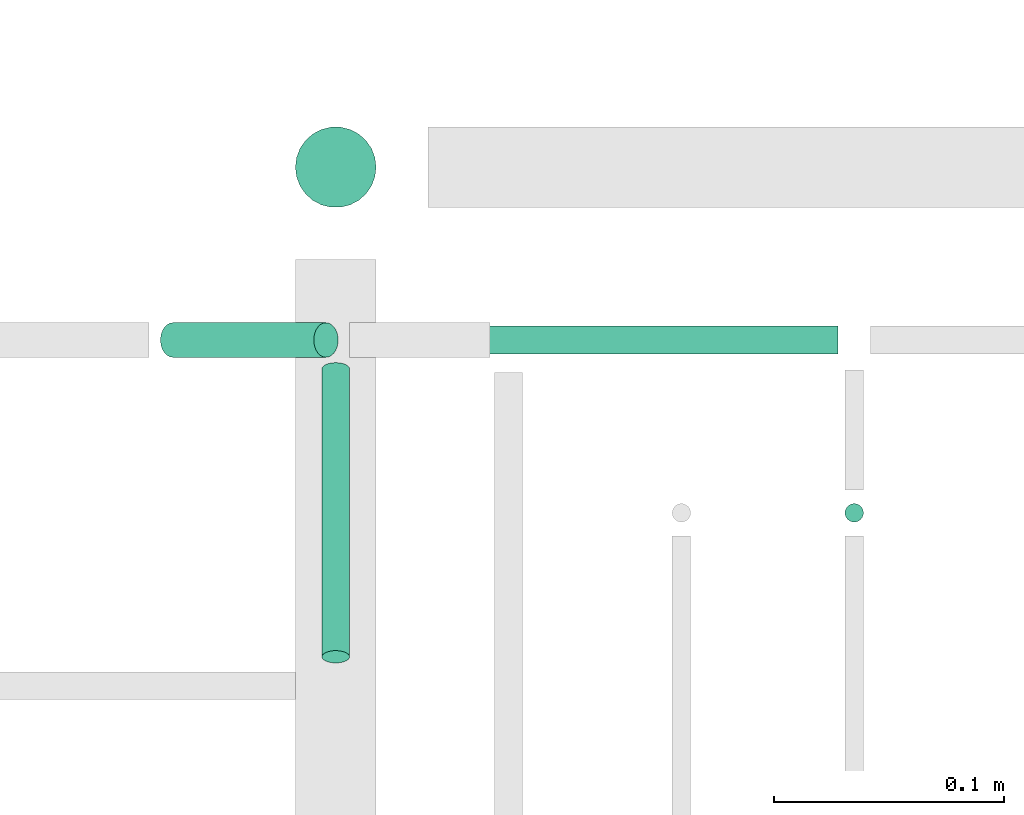
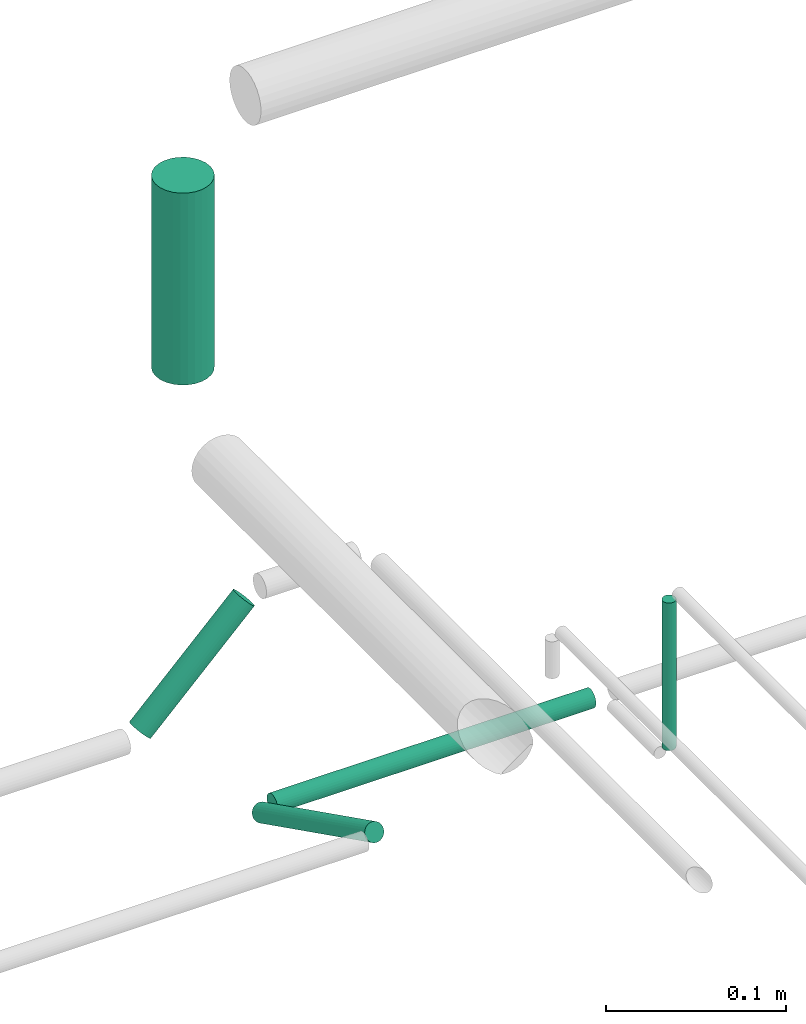
# One storey, part 133 of 331: 5 flow segments.
"""IFC2X3 building model written with IfcOpenShell, lengths in millimetres."""

from ifc_helpers import new_model, entity, si_unit, converted_unit, derived_unit, direction, frame, frame_2d, origin, origin_2d_with_axis, place, context, subcontext, project, spatial, circle, extrude, type_object, element, save


model = new_model("IFC2X3")

# Units and contexts
model_context = context("Model", 3, precision=0.01, world=origin(), true_north=direction((6.12303176911189e-17, 1.0)))
body_context = subcontext(model_context, "Body", "Model", "MODEL_VIEW")
ifc_project = project(units=[si_unit("LENGTHUNIT", "METRE", prefix="MILLI"), si_unit("AREAUNIT", "SQUARE_METRE"), si_unit("VOLUMEUNIT", "CUBIC_METRE"), converted_unit("PLANEANGLEUNIT", "DEGREE", entity("IfcRatioMeasure", 0.0174532925199433), si_unit("PLANEANGLEUNIT", "RADIAN"), dimensions=[0, 0, 0, 0, 0, 0, 0]), si_unit("MASSUNIT", "GRAM", prefix="KILO"), derived_unit("MASSDENSITYUNIT", [(si_unit("MASSUNIT", "GRAM", prefix="KILO"), 1), (si_unit("LENGTHUNIT", "METRE"), -3)]), derived_unit("MOMENTOFINERTIAUNIT", [(si_unit("LENGTHUNIT", "METRE"), 4)]), si_unit("TIMEUNIT", "SECOND"), si_unit("FREQUENCYUNIT", "HERTZ"), si_unit("THERMODYNAMICTEMPERATUREUNIT", "DEGREE_CELSIUS"), derived_unit("THERMALTRANSMITTANCEUNIT", [(si_unit("MASSUNIT", "GRAM", prefix="KILO"), 1), (si_unit("THERMODYNAMICTEMPERATUREUNIT", "KELVIN"), -1), (si_unit("TIMEUNIT", "SECOND"), -3)]), derived_unit("VOLUMETRICFLOWRATEUNIT", [(si_unit("LENGTHUNIT", "METRE"), 3), (si_unit("TIMEUNIT", "SECOND"), -1)]), derived_unit("MASSFLOWRATEUNIT", [(si_unit("MASSUNIT", "GRAM", prefix="KILO"), 1), (si_unit("TIMEUNIT", "SECOND"), -1)]), derived_unit("ROTATIONALFREQUENCYUNIT", [(si_unit("TIMEUNIT", "SECOND"), -1)]), si_unit("ELECTRICCURRENTUNIT", "AMPERE"), si_unit("ELECTRICVOLTAGEUNIT", "VOLT"), si_unit("POWERUNIT", "WATT"), si_unit("FORCEUNIT", "NEWTON", prefix="KILO"), si_unit("ILLUMINANCEUNIT", "LUX"), si_unit("LUMINOUSFLUXUNIT", "LUMEN"), si_unit("LUMINOUSINTENSITYUNIT", "CANDELA"), derived_unit("USERDEFINED", [(si_unit("MASSUNIT", "GRAM", prefix="KILO"), -1), (si_unit("LENGTHUNIT", "METRE"), -2), (si_unit("TIMEUNIT", "SECOND"), 3), (si_unit("LUMINOUSFLUXUNIT", "LUMEN"), 1)]), derived_unit("LINEARVELOCITYUNIT", [(si_unit("LENGTHUNIT", "METRE"), 1), (si_unit("TIMEUNIT", "SECOND"), -1)]), si_unit("PRESSUREUNIT", "PASCAL"), derived_unit("USERDEFINED", [(si_unit("LENGTHUNIT", "METRE"), -2), (si_unit("MASSUNIT", "GRAM", prefix="KILO"), 1), (si_unit("TIMEUNIT", "SECOND"), -2)]), derived_unit("LINEARFORCEUNIT", [(si_unit("MASSUNIT", "GRAM", prefix="KILO"), 1), (si_unit("LENGTHUNIT", "METRE"), 1), (si_unit("TIMEUNIT", "SECOND"), -2), (si_unit("LENGTHUNIT", "METRE"), -1)]), derived_unit("PLANARFORCEUNIT", [(si_unit("MASSUNIT", "GRAM", prefix="KILO"), 1), (si_unit("LENGTHUNIT", "METRE"), 1), (si_unit("TIMEUNIT", "SECOND"), -2), (si_unit("LENGTHUNIT", "METRE"), -2)])], contexts=[model_context])

# Site, building, storey
site_placement = place(None, frame((0.0, -0.00077364408347762, 0.0)))
site = spatial("IfcSite", under=ifc_project, at=site_placement, CompositionType="ELEMENT")
building_placement = place(site_placement, origin())
building = spatial("IfcBuilding", under=site, at=building_placement, CompositionType="ELEMENT")
storey_placement = place(building_placement, origin())
storey = spatial("IfcBuildingStorey", under=building, at=storey_placement, CompositionType="ELEMENT", Elevation=0.0)

# Flow segments
pipe_segment_type = type_object("IfcPipeSegmentType", PredefinedType="NOTDEFINED")
flow_segment_1_placement = place(storey_placement, frame((20840.733655358, 9194.40472776408, 18460.0)))
element("IfcFlowSegment", 1, at=flow_segment_1_placement, inside=storey, type_object=pipe_segment_type, context=body_context, shape_type="SweptSolid", body=[
    extrude(circle(Radius=4.0, at=frame_2d((0.0, -1.08286712929839e-12), x_axis=(1.0, 0.0))), frame((5.59527223591499, 5.59527223591716, 0.0)), (0.0, 0.0, 1.0), 99.9999999999556),
])
flow_segment_2_placement = place(storey_placement, frame((20602.233655511, 9330.9047277643, 18705.0)))
element("IfcFlowSegment", 2, at=flow_segment_2_placement, inside=storey, type_object=pipe_segment_type, context=body_context, shape_type="SweptSolid", body=[
    extrude(circle(Radius=17.5, at=origin_2d_with_axis()), frame((19.0952722359163, 19.0952722359163, 0.0), z_axis=(0.0, 0.0, 1.0), x_axis=(-1.0, 0.0, 0.0)), (0.0, 0.0, 1.0), 129.996500831214),
])
flow_segment_3_placement = place(storey_placement, frame((20635.328927594, 9267.40472776407, 18442.4047277641)))
element("IfcFlowSegment", 3, at=flow_segment_3_placement, inside=storey, type_object=pipe_segment_type, context=body_context, shape_type="SweptSolid", body=[
    extrude(circle(Radius=6.0, at=frame_2d((2.16573425859679e-12, 0.0), x_axis=(1.0, 0.0))), frame((0.0, 7.59527223591778, 7.5952722359167), z_axis=(1.0, 0.0, 0.0), x_axis=(0.0, 1.0, 0.0)), (0.0, 0.0, 1.0), 204.000000000014),
])
flow_segment_4_placement = place(building_placement, frame((20543.6729951858, 9265.9047277642, 18522.3440675924)))
element("IfcFlowSegment", 4, at=flow_segment_4_placement, inside=storey, type_object=pipe_segment_type, context=body_context, shape_type="SweptSolid", body=[
    extrude(circle(Radius=7.5, at=origin_2d_with_axis()), frame((6.89857309481563, 9.09527223591636, 6.89857309481346), z_axis=(0.707106781186455, 0.0, 0.70710678118664), x_axis=(0.0, 1.0, 0.0)), (0.0, 0.0, 1.0), 94.0660171787076),
])
flow_segment_5_placement = place(building_placement, frame((20613.7336553581, 9133.24342686508, 18449.2991549551)))
element("IfcFlowSegment", 5, at=flow_segment_5_placement, inside=storey, type_object=pipe_segment_type, context=body_context, shape_type="SweptSolid", body=[
    extrude(circle(Radius=6.0, at=frame_2d((0.0, -1.93709160936878e-12), x_axis=(1.0, 0.0))), frame((7.59527223591454, 4.27855380891562, 69.4398547079444), z_axis=(0.0, 0.894427190999811, -0.447213595500169), x_axis=(1.0, 0.0, 0.0)), (0.0, 0.0, 1.0), 139.705098312491),
])

save(model, "model.ifc")
